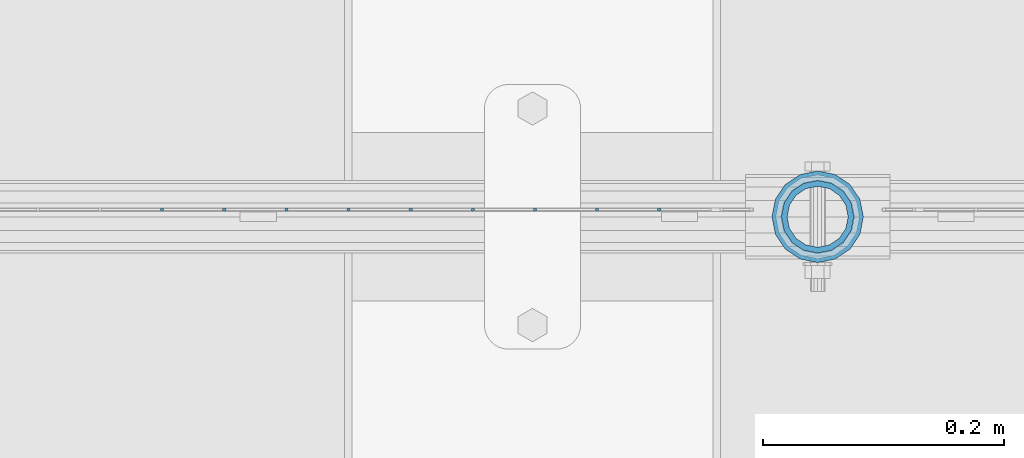
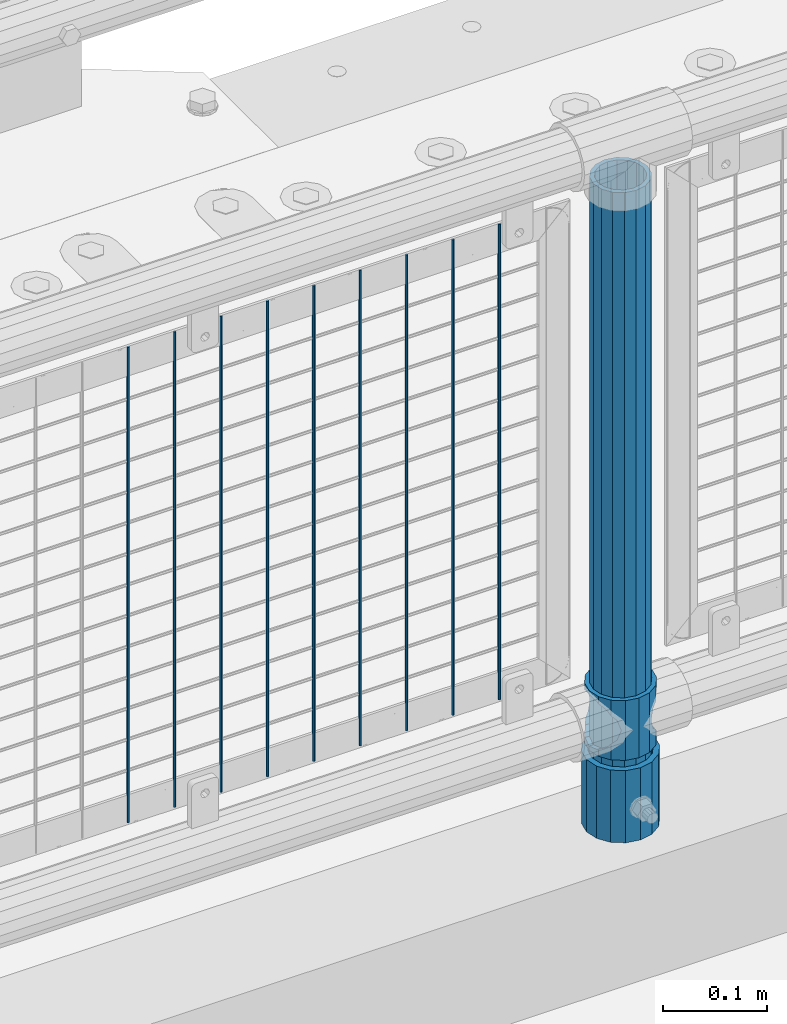
# One storey, part 69 of 219: 12 columns.
"""IFC2X3 building model written with IfcOpenShell, lengths in millimetres."""

from ifc_helpers import new_model, si_unit, frame, origin_with_axes, place, context, subcontext, project, spatial, faceted_brep, material, type_object, element, save


model = new_model("IFC2X3")

# Units and contexts
model_context = context("Model", 3, precision=1e-05, world=origin_with_axes())
body_context = subcontext(model_context, "Body", "Model", "MODEL_VIEW")
ifc_project = project(units=[si_unit("LENGTHUNIT", "METRE", prefix="MILLI"), si_unit("AREAUNIT", "SQUARE_METRE"), si_unit("VOLUMEUNIT", "CUBIC_METRE"), si_unit("MASSUNIT", "GRAM", prefix="KILO"), si_unit("TIMEUNIT", "SECOND"), si_unit("PLANEANGLEUNIT", "RADIAN"), si_unit("SOLIDANGLEUNIT", "STERADIAN"), si_unit("THERMODYNAMICTEMPERATUREUNIT", "DEGREE_CELSIUS"), si_unit("LUMINOUSINTENSITYUNIT", "LUMEN")], contexts=[model_context])

# Site, building, storey
site_placement = place(None, origin_with_axes())
site = spatial("IfcSite", under=ifc_project, at=site_placement, CompositionType="ELEMENT")
building_placement = place(site_placement, origin_with_axes())
building = spatial("IfcBuilding", under=site, at=building_placement, Name="Standard", CompositionType="ELEMENT")
storey_placement = place(building_placement, origin_with_axes())
storey = spatial("IfcBuildingStorey", under=building, at=storey_placement, Name="Undefined", CompositionType="ELEMENT", Elevation=0.0)

# Columns
ifc_material_1 = material(Name="Misc_Undefined")
column_type_1 = type_object("IfcColumnType", PredefinedType="NOTDEFINED")
column_1_placement = place(storey_placement, frame((3937.0, 31664.5, 263.02), z_axis=(-1.0, 0.0, 0.0), x_axis=(0.0, 0.0, 1.0)))
element("IfcColumn", 1, at=column_1_placement, inside=storey, type_object=column_type_1, material=ifc_material_1, context=body_context, shape_type="Brep", body=[
    faceted_brep([(56.6106908090114, 21.46069080901, -21.4606908090118), (56.6106908090114, 21.46069080901, -27.1226768591096), (61.9623795176703, 13.4513226476338, -32.4743655677721), (63.1897438117172, 11.614442172282, -32.8397438117172), (63.1897438117172, 11.614442172282, -28.0397438117179), (46.7644421722801, 28.0397438117179, -11.6144421722802), (46.7644421722801, 28.0397438117179, -20.0882031229849), (51.5310424080006, 24.8548033587067, -24.8548033587067), (35.1499999999996, 30.35, 0.0), (35.1499999999996, 30.3499999999985, -16.6306603983739), (23.5355578277192, 28.0397438117179, -11.6144421722802), (23.5355578277192, 28.0397438117179, -20.0882031229849), (13.6893091909879, 21.46069080901, -21.4606908090118), (13.6893091909879, 21.46069080901, -27.1226768591096), (18.7689575919987, 24.8548033587067, -24.8548033587067), (7.11025618828211, 11.614442172282, -28.0397438117179), (7.11025618828211, 11.614442172282, -32.8397438117172), (8.33762048232455, 13.4513226476338, -32.4743655677721), (4.79999999999961, 0.0, -30.3500000000004), (4.79999999999961, 0.0, -35.1499999999996), (7.11025618828211, -11.614442172282, -28.0397438117179), (7.11025618828211, -11.614442172282, -32.839743811719), (13.6893091909879, -21.46069080901, -21.4606908090118), (13.6893091909879, -21.46069080901, -27.1226768591077), (8.33762048232455, -13.4513226476338, -32.4743655677721), (23.5355578277191, -28.0397438117179, -11.6144421722802), (23.5355578277191, -28.0397438117179, -20.0882031229739), (18.7689575919921, -24.8548033587067, -24.8548033587067), (35.1499999999996, -30.35, 0.0), (35.1499999999996, -30.3499999999985, -16.6306603983649), (46.7644421722801, -28.0397438117179, -11.6144421722802), (46.7644421722801, -28.0397438117179, -20.0882031229739), (56.6106908090114, -21.46069080901, -21.4606908090118), (56.6106908090114, -21.46069080901, -27.1226768591077), (51.5310424080006, -24.8548033587067, -24.8548033587067), (63.1897438117172, -11.614442172282, -28.0397438117179), (63.1897438117172, -11.614442172282, -32.839743811719), (61.9623795176747, -13.4513226476338, -32.4743655677721), (65.4999999999997, 0.0, -30.3500000000004), (65.4999999999997, 0.0, -35.1499999999996), (0.0, -28.0397438117179, -11.6144421722802), (0.0, -30.3499999999985, 0.0), (0.0, -21.46069080901, -21.4606908090118), (0.0, -11.614442172282, -28.0397438117179), (0.0, 0.0, -30.3500000000004), (0.0, 11.614442172282, -28.0397438117179), (0.0, 21.46069080901, -21.4606908090118), (0.0, 28.0397438117179, -11.6144421722802), (0.0, 30.3499999999985, 0.0), (0.0, 28.0397438117179, 11.6144421722802), (23.5355578277192, 28.0397438117179, 11.6144421722806), (0.0, 21.46069080901, 21.4606908090118), (13.6893091909879, 21.46069080901, 21.4606908090118), (0.0, 11.614442172282, 28.0397438117179), (7.11025618828211, 11.614442172282, 28.0397438117175), (0.0, 0.0, 30.3500000000004), (4.79999999999961, 0.0, 30.3499999999999), (0.0, -11.614442172282, 28.0397438117179), (7.11025618828205, -11.614442172282, 28.0397438117175), (0.0, -21.46069080901, 21.4606908090118), (13.6893091909879, -21.46069080901, 21.4606908090118), (0.0, -28.0397438117179, 11.6144421722802), (23.5355578277191, -28.0397438117179, 11.6144421722806), (0.0, -32.4743655677703, 13.4513226476338), (0.0, -35.1500000000015, 0.0), (70.2999999999993, -35.1500000000015, 0.0), (70.2999999999993, -32.4743655677703, 13.4513226476338), (0.0, 13.4513226476338, -32.4743655677721), (0.0, 24.8548033587067, -24.8548033587067), (0.0, 0.0, -35.1500000000015), (0.0, -13.4513226476338, -32.4743655677721), (0.0, -24.8548033587067, -24.8548033587067), (0.0, -24.8548033587067, 24.8548033587067), (0.0, -13.4513226476338, 32.4743655677721), (0.0, 0.0, 35.1500000000015), (0.0, 13.4513226476338, 32.4743655677721), (0.0, 24.8548033587067, 24.8548033587067), (0.0, 32.4743655677703, 13.4513226476338), (0.0, 35.1500000000015, 0.0), (0.0, 32.4743655677703, -13.4513226476338), (0.0, -32.4743655677703, -13.4513226476338), (70.2999999999993, 32.4743655677703, 13.4513226476338), (70.2999999999993, 35.1500000000015, 0.0), (70.2999999999993, 32.4743655677703, -13.4513226476338), (70.2999999999993, 24.8548033587067, -24.8548033587067), (70.2999999999993, 13.4513226476338, -32.4743655677721), (70.2999999999993, 0.0, -35.1499999999996), (70.2999999999993, -13.4513226476338, -32.4743655677721), (70.2999999999993, -24.8548033587067, -24.8548033587067), (70.2999999999993, -32.4743655677703, -13.4513226476338), (70.2999999999993, 28.0397438117179, 11.6144421722802), (70.2999999999993, 21.46069080901, 21.4606908090118), (56.6106908090114, 21.46069080901, 21.4606908090118), (46.7644421722801, 28.0397438117179, 11.6144421722806), (70.2999999999993, 11.614442172282, 28.0397438117179), (63.1897438117172, 11.614442172282, 28.0397438117175), (70.2999999999993, 0.0, 30.3500000000004), (65.4999999999997, 0.0, 30.3499999999999), (70.2999999999993, -11.614442172282, 28.0397438117179), (63.1897438117172, -11.614442172282, 28.0397438117175), (70.2999999999993, -21.46069080901, 21.4606908090118), (56.6106908090114, -21.46069080901, 21.4606908090118), (70.2999999999993, -28.0397438117179, 11.6144421722802), (46.7644421722801, -28.0397438117179, 11.6144421722806), (70.2999999999993, -11.614442172282, -28.0397438117179), (70.2999999999993, 0.0, -30.3500000000004), (70.2999999999993, -21.46069080901, -21.4606908090118), (70.2999999999993, -28.0397438117179, -11.6144421722802), (70.2999999999993, -30.3499999999985, 0.0), (70.2999999999993, 24.8548033587067, 24.8548033587067), (70.2999999999993, 13.4513226476338, 32.4743655677721), (70.2999999999993, 0.0, 35.1499999999996), (70.2999999999993, -13.4513226476338, 32.4743655677721), (70.2999999999993, -24.8548033587067, 24.8548033587067), (70.2999999999993, 30.3499999999985, 0.0), (70.2999999999993, 28.0397438117179, -11.6144421722802), (70.2999999999993, 21.46069080901, -21.4606908090118), (70.2999999999993, 11.614442172282, -28.0397438117179), (61.9623795176742, 13.4513226476338, 32.4743655677717), (51.5310424080006, 24.8548033587067, 24.8548033587072), (56.6106908090114, 21.46069080901, 27.1226768591059), (65.4999999999997, 0.0, 35.1500000000001), (63.1897438117172, 11.614442172282, 32.8397438117177), (63.1897438117172, -11.614442172282, 32.8397438117177), (61.9623795176742, -13.4513226476338, 32.4743655677717), (56.6106908090114, -21.46069080901, 27.1226768591087), (51.5310424080006, -24.8548033587067, 24.8548033587072), (18.7689575919921, -24.8548033587067, 24.8548033587072), (46.7644421722801, -28.0397438117179, 20.0882031229862), (35.1499999999996, -30.3499999999985, 16.630660398373), (23.5355578277191, -28.0397438117179, 20.0882031229862), (8.33762048232506, -13.4513226476338, 32.4743655677717), (13.6893091909879, -21.46069080901, 27.1226768591087), (4.79999999999961, 0.0, 35.1500000000001), (7.11025618828205, -11.614442172282, 32.8397438117177), (7.11025618828211, 11.614442172282, 32.8397438117177), (8.33762048232069, 13.4513226476338, 32.4743655677717), (13.6893091909879, 21.46069080901, 27.1226768591059), (18.7689575919987, 24.8548033587067, 24.8548033587072), (23.5355578277192, 28.0397438117179, 20.0882031229794), (35.1499999999996, 30.3499999999985, 16.6306603983667), (46.7644421722801, 28.0397438117179, 20.0882031229794)], [[[0, 1, 2, 3, 4]], [[5, 6, 7, 1, 0]], [[8, 9, 6, 5]], [[10, 11, 9, 8]], [[12, 13, 14, 11, 10]], [[15, 16, 17, 13, 12]], [[18, 19, 16, 15]], [[20, 21, 19, 18]], [[22, 23, 24, 21, 20]], [[25, 26, 27, 23, 22]], [[28, 29, 26, 25]], [[30, 31, 29, 28]], [[32, 33, 34, 31, 30]], [[35, 36, 37, 33, 32]], [[38, 39, 36, 35]], [[4, 3, 39, 38]], [[40, 41, 28, 25]], [[42, 40, 25, 22]], [[43, 42, 22, 20]], [[44, 43, 20, 18]], [[45, 44, 18, 15]], [[46, 45, 15, 12]], [[47, 46, 12, 10]], [[48, 47, 10, 8]], [[49, 48, 8, 50]], [[51, 49, 50, 52]], [[53, 51, 52, 54]], [[55, 53, 54, 56]], [[57, 55, 56, 58]], [[59, 57, 58, 60]], [[61, 59, 60, 62]], [[41, 61, 62, 28]], [[63, 64, 65, 66]], [[17, 67, 68, 14, 13]], [[19, 69, 67, 17, 16]], [[70, 69, 19, 21, 24]], [[71, 70, 24, 23, 27]], [[63, 72, 73, 74, 75, 76, 77, 78, 79, 68, 67, 69, 70, 71, 80, 64], [40, 42, 43, 44, 45, 46, 47, 48, 49, 51, 53, 55, 57, 59, 61, 41]], [[78, 77, 81, 82]], [[79, 78, 82, 83]], [[14, 68, 79, 83, 84, 7, 6, 9, 11]], [[84, 85, 2, 1, 7]], [[85, 86, 39, 3, 2]], [[37, 87, 88, 34, 33]], [[39, 86, 87, 37, 36]], [[34, 88, 89, 80, 71, 27, 26, 29, 31]], [[64, 80, 89, 65]], [[90, 91, 92, 93]], [[91, 94, 95, 92]], [[94, 96, 97, 95]], [[96, 98, 99, 97]], [[98, 100, 101, 99]], [[100, 102, 103, 101]], [[104, 105, 38, 35]], [[106, 104, 35, 32]], [[107, 106, 32, 30]], [[108, 107, 30, 28]], [[102, 108, 28, 103]], [[88, 87, 86, 85, 84, 83, 82, 81, 109, 110, 111, 112, 113, 66, 65, 89], [100, 98, 96, 94, 91, 90, 114, 115, 116, 117, 105, 104, 106, 107, 108, 102]], [[118, 110, 109, 119, 120]], [[121, 111, 110, 118, 122]], [[112, 111, 121, 123, 124]], [[113, 112, 124, 125, 126]], [[127, 72, 63, 66, 113, 126, 128, 129, 130]], [[131, 73, 72, 127, 132]], [[133, 74, 73, 131, 134]], [[75, 74, 133, 135, 136]], [[76, 75, 136, 137, 138]], [[119, 109, 81, 77, 76, 138, 139, 140, 141]], [[92, 120, 119, 141, 93]], [[95, 122, 118, 120, 92]], [[97, 121, 122, 95]], [[99, 123, 121, 97]], [[101, 125, 124, 123, 99]], [[103, 128, 126, 125, 101]], [[28, 129, 128, 103]], [[62, 130, 129, 28]], [[60, 132, 127, 130, 62]], [[58, 134, 131, 132, 60]], [[56, 133, 134, 58]], [[54, 135, 133, 56]], [[52, 137, 136, 135, 54]], [[50, 139, 138, 137, 52]], [[8, 140, 139, 50]], [[93, 141, 140, 8]], [[114, 90, 93, 8]], [[115, 114, 8, 5]], [[116, 115, 5, 0]], [[117, 116, 0, 4]], [[105, 117, 4, 38]]]),
])
ifc_material_2 = material()
column_type_2 = type_object("IfcColumnType", PredefinedType="NOTDEFINED")
column_2_placement = place(storey_placement, frame((3937.0, 31664.5, 168.02), z_axis=(-1.0, 0.0, 0.0), x_axis=(0.0, 0.0, 1.0)))
element("IfcColumn", 2, at=column_2_placement, inside=storey, type_object=column_type_2, material=ifc_material_2, context=body_context, shape_type="Brep", body=[
    faceted_brep([(0.0, -25.3499999999985, 0.0), (0.0, -23.4203461491597, 9.70102501045585), (760.0, -23.4203461491597, 9.70102501045585), (760.0, -25.3499999999985, 0.0), (0.0, -17.9251569030785, 17.9251569030785), (760.0, -17.9251569030785, 17.9251569030785), (0.0, -9.70102501045403, 23.4203461491616), (760.0, -9.70102501045403, 23.4203461491616), (0.0, 0.0, 25.3500000000004), (760.0, 0.0, 25.3500000000004), (0.0, 9.70102501045403, 23.4203461491616), (760.0, 9.70102501045403, 23.4203461491616), (0.0, 17.9251569030785, 17.9251569030785), (760.0, 17.9251569030785, 17.9251569030785), (0.0, 23.4203461491597, 9.70102501045585), (760.0, 23.4203461491597, 9.70102501045585), (0.0, 25.3499999999985, 0.0), (760.0, 25.3499999999985, 0.0), (0.0, 23.4203461491597, -9.70102501045585), (760.0, 23.4203461491597, -9.70102501045585), (0.0, 17.9251569030785, -17.9251569030785), (760.0, 17.9251569030785, -17.9251569030785), (0.0, 9.70102501045403, -23.4203461491616), (760.0, 9.70102501045403, -23.4203461491616), (0.0, 0.0, -25.3500000000004), (760.0, 0.0, -25.3500000000004), (0.0, -9.70102501045403, -23.4203461491616), (760.0, -9.70102501045403, -23.4203461491616), (0.0, -17.9251569030785, -17.9251569030785), (760.0, -17.9251569030785, -17.9251569030785), (0.0, -23.4203461491597, -9.70102501045585), (760.0, -23.4203461491597, -9.70102501045585), (0.0, -30.1500000000015, 0.0), (0.0, -27.8549679052157, -11.5379054858076), (760.0, -27.8549679052157, -11.5379054858076), (760.0, -30.1500000000015, 0.0), (0.0, -21.3192694527752, -21.3192694527752), (760.0, -21.3192694527752, -21.3192694527752), (0.0, -11.5379054858058, -27.8549679052157), (760.0, -11.5379054858058, -27.8549679052157), (0.0, 0.0, -30.1499999999996), (760.0, 0.0, -30.1499999999996), (0.0, 11.5379054858058, -27.8549679052157), (760.0, 11.5379054858058, -27.8549679052157), (0.0, 21.3192694527752, -21.3192694527752), (760.0, 21.3192694527752, -21.3192694527752), (0.0, 27.8549679052157, -11.5379054858076), (760.0, 27.8549679052157, -11.5379054858076), (0.0, 30.1500000000015, 0.0), (760.0, 30.1500000000015, 0.0), (0.0, 27.8549679052157, 11.5379054858076), (760.0, 27.8549679052157, 11.5379054858076), (0.0, 21.3192694527752, 21.3192694527752), (760.0, 21.3192694527752, 21.3192694527752), (0.0, 11.5379054858058, 27.8549679052157), (760.0, 11.5379054858058, 27.8549679052157), (0.0, 0.0, 30.1499999999996), (760.0, 0.0, 30.1499999999996), (0.0, -11.5379054858058, 27.8549679052157), (760.0, -11.5379054858058, 27.8549679052157), (0.0, -21.3192694527752, 21.3192694527752), (760.0, -21.3192694527752, 21.3192694527752), (0.0, -27.8549679052157, 11.5379054858076), (760.0, -27.8549679052157, 11.5379054858076)], [[[0, 1, 2, 3]], [[1, 4, 5, 2]], [[4, 6, 7, 5]], [[6, 8, 9, 7]], [[8, 10, 11, 9]], [[10, 12, 13, 11]], [[12, 14, 15, 13]], [[14, 16, 17, 15]], [[16, 18, 19, 17]], [[18, 20, 21, 19]], [[20, 22, 23, 21]], [[22, 24, 25, 23]], [[24, 26, 27, 25]], [[26, 28, 29, 27]], [[28, 30, 31, 29]], [[30, 0, 3, 31]], [[32, 33, 34, 35]], [[33, 36, 37, 34]], [[36, 38, 39, 37]], [[38, 40, 41, 39]], [[40, 42, 43, 41]], [[42, 44, 45, 43]], [[44, 46, 47, 45]], [[46, 48, 49, 47]], [[48, 50, 51, 49]], [[50, 52, 53, 51]], [[52, 54, 55, 53]], [[54, 56, 57, 55]], [[56, 58, 59, 57]], [[58, 60, 61, 59]], [[60, 62, 63, 61]], [[62, 32, 35, 63]], [[37, 39, 41, 43, 45, 47, 49, 51, 53, 55, 57, 59, 61, 63, 35, 34], [5, 7, 9, 11, 13, 15, 17, 19, 21, 23, 25, 27, 29, 31, 3, 2]], [[62, 60, 58, 56, 54, 52, 50, 48, 46, 44, 42, 40, 38, 36, 33, 32], [30, 28, 26, 24, 22, 20, 18, 16, 14, 12, 10, 8, 6, 4, 1, 0]]]),
])
column_type_3 = type_object("IfcColumnType", PredefinedType="NOTDEFINED")
column_3_placement = place(storey_placement, frame((3937.0, 31664.5, 168.02), z_axis=(0.0, 1.0, 0.0), x_axis=(0.0, 0.0, 1.0)))
element("IfcColumn", 3, at=column_3_placement, inside=storey, type_object=column_type_3, material=ifc_material_2, context=body_context, shape_type="Brep", body=[
    faceted_brep([(0.0, -31.75, 0.0), (0.0, -29.3331751572332, 12.1501989775934), (85.0, -29.3331751572332, 12.1501989775934), (85.0, -31.75, 0.0), (0.0, -22.4506403026735, 22.4506403026717), (85.0, -22.4506403026735, 22.4506403026717), (0.0, -12.1501989775916, 29.3331751572332), (85.0, -12.1501989775916, 29.3331751572332), (0.0, 0.0, 31.75), (85.0, 0.0, 31.75), (0.0, 12.1501989775916, 29.3331751572332), (85.0, 12.1501989775916, 29.3331751572332), (0.0, 22.4506403026735, 22.4506403026717), (85.0, 22.4506403026735, 22.4506403026717), (0.0, 29.3331751572332, 12.1501989775934), (85.0, 29.3331751572332, 12.1501989775934), (0.0, 31.75, 0.0), (85.0, 31.75, 0.0), (0.0, 29.3331751572332, -12.1501989775934), (85.0, 29.3331751572332, -12.1501989775934), (0.0, 22.4506403026735, -22.4506403026717), (85.0, 22.4506403026735, -22.4506403026717), (0.0, 12.1501989775916, -29.3331751572332), (85.0, 12.1501989775916, -29.3331751572332), (0.0, 0.0, -31.75), (85.0, 0.0, -31.75), (0.0, -12.1501989775916, -29.3331751572332), (85.0, -12.1501989775916, -29.3331751572332), (0.0, -22.4506403026735, -22.4506403026717), (85.0, -22.4506403026735, -22.4506403026717), (0.0, -29.3331751572332, -12.1501989775934), (85.0, -29.3331751572332, -12.1501989775934), (0.0, -38.0499999999993, 0.0), (0.0, -35.1536162120537, -14.5611046014928), (85.0, -35.1536162120537, -14.5611046014928), (85.0, -38.0499999999993, 0.0), (0.0, -26.9054130241475, -26.9054130241493), (85.0, -26.9054130241475, -26.9054130241493), (0.0, -14.561104601491, -35.1536162120537), (85.0, -14.561104601491, -35.1536162120537), (0.0, 0.0, -38.0499999999993), (85.0, 0.0, -38.0499999999993), (0.0, 14.561104601491, -35.1536162120537), (85.0, 14.561104601491, -35.1536162120537), (0.0, 26.9054130241475, -26.9054130241493), (85.0, 26.9054130241475, -26.9054130241493), (0.0, 35.1536162120537, -14.5611046014928), (85.0, 35.1536162120537, -14.5611046014928), (0.0, 38.0499999999993, 0.0), (85.0, 38.0499999999993, 0.0), (0.0, 35.1536162120537, 14.5611046014928), (85.0, 35.1536162120537, 14.5611046014928), (0.0, 26.9054130241475, 26.9054130241493), (85.0, 26.9054130241475, 26.9054130241493), (0.0, 14.561104601491, 35.1536162120537), (85.0, 14.561104601491, 35.1536162120537), (0.0, 0.0, 38.0499999999993), (85.0, 0.0, 38.0499999999993), (0.0, -14.561104601491, 35.1536162120537), (85.0, -14.561104601491, 35.1536162120537), (0.0, -26.9054130241475, 26.9054130241493), (85.0, -26.9054130241475, 26.9054130241493), (0.0, -35.1536162120537, 14.5611046014928), (85.0, -35.1536162120537, 14.5611046014928)], [[[0, 1, 2, 3]], [[1, 4, 5, 2]], [[4, 6, 7, 5]], [[6, 8, 9, 7]], [[8, 10, 11, 9]], [[10, 12, 13, 11]], [[12, 14, 15, 13]], [[14, 16, 17, 15]], [[16, 18, 19, 17]], [[18, 20, 21, 19]], [[20, 22, 23, 21]], [[22, 24, 25, 23]], [[24, 26, 27, 25]], [[26, 28, 29, 27]], [[28, 30, 31, 29]], [[30, 0, 3, 31]], [[32, 33, 34, 35]], [[33, 36, 37, 34]], [[36, 38, 39, 37]], [[38, 40, 41, 39]], [[40, 42, 43, 41]], [[42, 44, 45, 43]], [[44, 46, 47, 45]], [[46, 48, 49, 47]], [[48, 50, 51, 49]], [[50, 52, 53, 51]], [[52, 54, 55, 53]], [[54, 56, 57, 55]], [[56, 58, 59, 57]], [[58, 60, 61, 59]], [[60, 62, 63, 61]], [[62, 32, 35, 63]], [[37, 39, 41, 43, 45, 47, 49, 51, 53, 55, 57, 59, 61, 63, 35, 34], [5, 7, 9, 11, 13, 15, 17, 19, 21, 23, 25, 27, 29, 31, 3, 2]], [[62, 60, 58, 56, 54, 52, 50, 48, 46, 44, 42, 40, 38, 36, 33, 32], [30, 28, 26, 24, 22, 20, 18, 16, 14, 12, 10, 8, 6, 4, 1, 0]]]),
])
column_type_4 = type_object("IfcColumnType", Name="D3", PredefinedType="NOTDEFINED")
for number, where, z_axis, x_axis in (
    (4, (3805.34, 31670.5, 353.02), (-1.0, 0.0, 0.0), (0.0, 0.0, 1.0)),
    (5, (3753.685, 31670.5, 353.02), (-1.0, 0.0, 0.0), (0.0, 0.0, 1.0)),
    (6, (3702.03, 31670.5, 353.02), (-1.0, 0.0, 0.0), (0.0, 0.0, 1.0)),
    (7, (3650.375, 31670.5, 353.02), (-1.0, 0.0, 0.0), (0.0, 0.0, 1.0)),
    (8, (3598.72, 31670.5, 353.02), (-1.0, 0.0, 0.0), (0.0, 0.0, 1.0)),
    (9, (3547.065, 31670.5, 353.02), (-1.0, 0.0, 0.0), (0.0, 0.0, 1.0)),
    (10, (3495.41, 31670.5, 353.02), (-1.0, 0.0, 0.0), (0.0, 0.0, 1.0)),
    (11, (3443.755, 31670.5, 353.02), (-1.0, 0.0, 0.0), (0.0, 0.0, 1.0)),
    (12, (3392.1, 31670.5, 353.02), (-1.0, 0.0, 0.0), (0.0, 0.0, 1.0)),
):
    element("IfcColumn", number, at=place(storey_placement, frame(where, z_axis=z_axis, x_axis=x_axis)), inside=storey, type_object=column_type_4, material=ifc_material_1, ObjectType="D3", context=body_context, shape_type="Brep", body=[
        faceted_brep([(0.0, -1.5, -5.6843418860808e-14), (0.0, -0.75, -1.29903810567669), (560.0, -0.75, -1.29903810567703), (560.0, -1.5, 0.0), (0.0, 0.75, -1.29903810567669), (560.0, 0.75, -1.29903810567703), (0.0, 1.5, -5.6843418860808e-14), (560.0, 1.5, 0.0), (0.0, 0.75, 1.29903810567669), (560.0, 0.75, 1.29903810567703), (0.0, -0.75, 1.29903810567669), (560.0, -0.75, 1.29903810567703)], [[[0, 1, 2, 3]], [[1, 4, 5, 2]], [[4, 6, 7, 5]], [[6, 8, 9, 7]], [[8, 10, 11, 9]], [[10, 0, 3, 11]], [[5, 7, 9, 11, 3, 2]], [[10, 8, 6, 4, 1, 0]]]),
    ])

save(model, "model.ifc")
